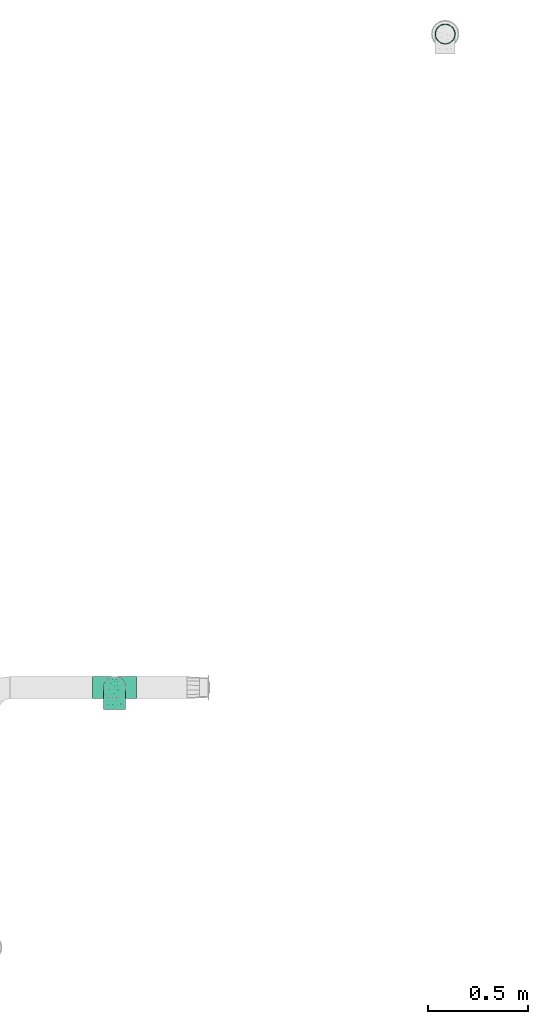
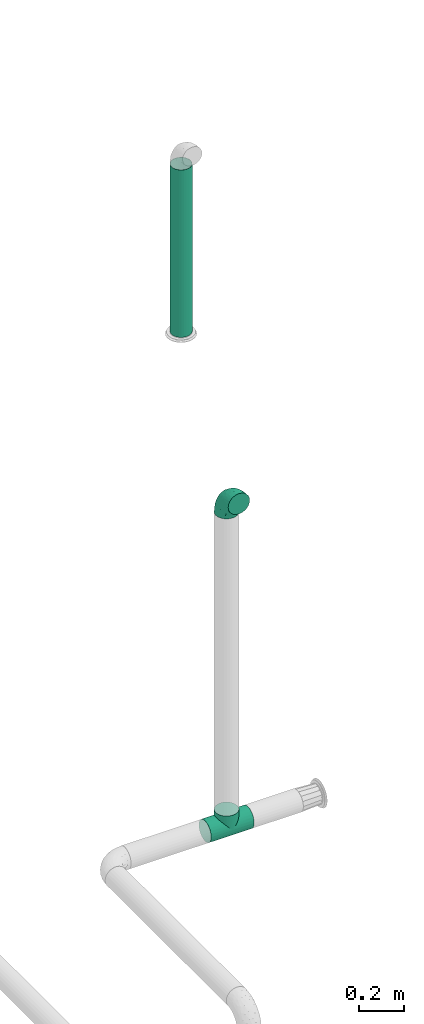
# One storey, part 45 of 103: 2 flow fittings, 1 flow segment.
"""IFC2X3 building model written with IfcOpenShell, lengths in millimetres."""

from ifc_helpers import new_model, entity, si_unit, converted_unit, derived_unit, direction, frame, origin_with_axes, origin_2d_with_axis, place, context, subcontext, project, spatial, hollow_circle, extrude, open_shell, surface_model, source, transform, mapped, material, layer, layer_set, layer_usage, type_object, element, save


model = new_model("IFC2X3")

# Units and contexts
model_context = context("Model", 3, precision=1e-05, world=origin_with_axes(), true_north=direction((0.0, 1.0)))
body_context = subcontext(model_context, "Body", "Model", "MODEL_VIEW")
ifc_project = project(units=[si_unit("AREAUNIT", "SQUARE_METRE"), si_unit("VOLUMEUNIT", "CUBIC_METRE", prefix="DECI"), si_unit("TIMEUNIT", "SECOND"), si_unit("THERMODYNAMICTEMPERATUREUNIT", "DEGREE_CELSIUS"), si_unit("PRESSUREUNIT", "PASCAL"), si_unit("MASSUNIT", "GRAM", prefix="KILO"), si_unit("LENGTHUNIT", "METRE", prefix="MILLI"), si_unit("POWERUNIT", "WATT"), si_unit("ELECTRICCURRENTUNIT", "AMPERE"), si_unit("ELECTRICVOLTAGEUNIT", "VOLT"), derived_unit("VOLUMETRICFLOWRATEUNIT", [(si_unit("VOLUMEUNIT", "CUBIC_METRE", prefix="DECI"), 1), (si_unit("TIMEUNIT", "SECOND"), -1)]), derived_unit("LINEARVELOCITYUNIT", [(si_unit("LENGTHUNIT", "METRE"), 1), (si_unit("TIMEUNIT", "SECOND"), -1)]), derived_unit("MASSDENSITYUNIT", [(si_unit("MASSUNIT", "GRAM", prefix="KILO"), 1), (si_unit("VOLUMEUNIT", "CUBIC_METRE"), -1)]), converted_unit("PLANEANGLEUNIT", "DEGREE", entity("IfcRatioMeasure", 0.01745), si_unit("PLANEANGLEUNIT", "RADIAN"), dimensions=[0, 0, 0, 0, 0, 0, 0])], contexts=[model_context])

# Site, building, storey
site_placement = place(None, origin_with_axes())
site = spatial("IfcSite", under=ifc_project, at=site_placement, CompositionType="ELEMENT")
building_placement = place(site_placement, origin_with_axes())
building = spatial("IfcBuilding", under=site, at=building_placement, Name="mc-building", CompositionType="ELEMENT")
storey_placement = place(building_placement, frame((0.0, 0.0, 5900.0), z_axis=(0.0, 0.0, 1.0), x_axis=(1.0, 0.0, 0.0)))
storey = spatial("IfcBuildingStorey", under=building, at=storey_placement, Name="3. Korrus", CompositionType="ELEMENT", Elevation=5900.0)

# Flow segment
ifc_material = material(Name="FZ1")
ifc_layer = layer(ifc_material, 0.0)
ifc_layer_set = layer_set([ifc_layer], Name="FZ1")
ifc_layer_usage = layer_usage(ifc_layer_set, "AXIS1", "POSITIVE", 0.0)
duct_segment_type = type_object("IfcDuctSegmentType", PredefinedType="RIGIDSEGMENT")
shared_shape_1 = source(origin_with_axes(), body_context, "Body", "SweptSolid", [
    extrude(hollow_circle(Radius=50.0, WallThickness=2.0, at=origin_2d_with_axis()), frame((0.0, 0.0, 0.0), z_axis=(1.0, 0.0, 0.0), x_axis=(0.0, 1.0, 0.0)), (0.0, 0.0, 1.0), 906.0),
])
flow_segment_placement = place(storey_placement, frame((14528.37491, 12733.41275, 2461.97044), z_axis=(1.0, 0.0, 0.0), x_axis=(0.0, 0.0, 1.0)))
element("IfcFlowSegment", 1, at=flow_segment_placement, inside=storey, type_object=duct_segment_type, material=ifc_layer_usage, context=body_context, shape_type="MappedRepresentation", body=[
    mapped(shared_shape_1, transform((0.0, 0.0, 0.0), scale=1.0)),
])

# Flow fittings
duct_fitting_type_1 = type_object("IfcDuctFittingType", PredefinedType="JUNCTION")
shared_shape_2 = source(origin_with_axes(), body_context, "Body", "SurfaceModel", [
    surface_model("IfcShellBasedSurfaceModel", [(-110.0, -38.89087, -38.89087), (-110.0, -55.0, 0.0), (-110.0, -27.5, -47.63139), (-110.0, -53.12592, -14.23505), (-110.0, -47.63139, -27.5), (-110.0, 47.63139, -27.5), (-110.0, 53.12592, 14.23505), (-110.0, 53.12592, -14.23505), (-110.0, 55.0, 0.0), (110.0, 38.89087, -38.89087), (110.0, 55.0, 0.0), (110.0, 27.5, -47.63139), (110.0, -38.89087, -38.89087), (110.0, -53.12592, 14.23505), (110.0, -47.63139, -27.5), (110.0, -55.0, 0.0), (110.0, -53.12592, -14.23505), (110.0, 53.12592, -14.23505), (110.0, 47.63139, -27.5), (-110.0, 38.89087, -38.89087), (-110.0, -14.23505, -53.12592), (-110.0, 0.0, -55.0), (-110.0, 27.5, -47.63139), (-110.0, 14.23505, -53.12592), (-110.0, -53.12592, 14.23505), (-110.0, -47.63139, 27.5), (-110.0, -38.89087, 38.89087), (-110.0, 14.23505, 53.12592), (-110.0, 27.5, 47.63139), (-55.0, 80.0, 0.0), (0.0, 80.0, -55.0), (-14.23505, 80.0, -53.12592), (-27.5, 80.0, -47.63139), (-38.89087, 80.0, -38.89087), (-47.63139, 80.0, -27.5), (38.89087, 80.0, -38.89087), (53.12592, 80.0, 14.23505), (27.5, 80.0, -47.63139), (14.23505, 80.0, -53.12592), (47.63139, 80.0, -27.5), (53.12592, 80.0, -14.23505), (55.0, 80.0, 0.0), (-53.12592, 80.0, -14.23505), (-53.12592, 80.0, 14.23505), (-47.63139, 80.0, 27.5), (-38.89087, 80.0, 38.89087), (0.0, 80.0, 55.0), (-27.5, 80.0, 47.63139), (-14.23505, 80.0, 53.12592), (47.63139, 80.0, 27.5), (38.89087, 80.0, 38.89087), (27.5, 80.0, 47.63139), (14.23505, 80.0, 53.12592), (-7.4066, 7.4066, 54.49901), (0.0, 0.0, 55.0), (-21.93978, 21.93978, 50.43457), (-14.74521, 14.74521, 52.98659), (-35.50357, 35.50357, 42.00591), (-28.89905, 28.89905, 46.79578), (-46.92319, 46.92319, 28.69171), (-41.58668, 41.58668, 35.99373), (-54.01174, 54.01174, 10.37938), (-54.06296, 80.0, 7.11752), (-55.0, 55.0, 0.0), (-51.19777, 51.19777, 20.0945), (-50.37866, 80.0, 20.86752), (-51.19777, 51.19777, -20.0945), (-54.01174, 54.01174, -10.37938), (-50.37866, 80.0, -20.86752), (-41.58668, 41.58668, -35.99373), (-46.92319, 46.92319, -28.69171), (-54.06296, 80.0, -7.11752), (-35.50357, 35.50357, -42.00591), (-14.74521, 14.74521, -52.98659), (-21.93978, 21.93978, -50.43457), (0.0, 0.0, -55.0), (-7.4066, 7.4066, -54.49901), (-28.89905, 28.89905, -46.79578), (7.4066, 7.4066, -54.49901), (21.93978, 21.93978, -50.43457), (14.74521, 14.74521, -52.98659), (35.50357, 35.50357, -42.00591), (28.89905, 28.89905, -46.79578), (46.92319, 46.92319, -28.69171), (41.58668, 41.58668, -35.99373), (54.01174, 54.01174, -10.37938), (54.06296, 80.0, -7.11752), (55.0, 55.0, 0.0), (51.19777, 51.19777, -20.0945), (50.37866, 80.0, -20.86752), (51.19777, 51.19777, 20.0945), (54.01174, 54.01174, 10.37938), (50.37866, 80.0, 20.86752), (41.58668, 41.58668, 35.99373), (46.92319, 46.92319, 28.69171), (54.06296, 80.0, 7.11752), (35.50357, 35.50357, 42.00591), (14.74521, 14.74521, 52.98659), (21.93978, 21.93978, 50.43457), (7.4066, 7.4066, 54.49901), (28.89905, 28.89905, 46.79578), (-110.0, -27.5, 47.63139), (-110.0, 0.0, 55.0), (-110.0, -14.23505, 53.12592), (-110.0, 47.63139, 27.5), (-110.0, 38.89087, 38.89087), (110.0, 0.0, -55.0), (110.0, 14.23505, -53.12592), (110.0, -14.23505, -53.12592), (110.0, -27.5, -47.63139), (110.0, 53.12592, 14.23505), (110.0, -47.63139, 27.5), (110.0, -38.89087, 38.89087), (110.0, 14.23505, 53.12592), (110.0, -27.5, 47.63139), (110.0, -14.23505, 53.12592), (110.0, 47.63139, 27.5), (110.0, 38.89087, 38.89087), (110.0, 27.5, 47.63139), (110.0, 0.0, 55.0)], [open_shell([[[0, 1, 2]], [[3, 1, 4]], [[5, 6, 7]], [[8, 7, 6]], [[9, 10, 11]], [[12, 13, 14]], [[15, 16, 13]], [[17, 10, 18]], [[19, 6, 5]], [[2, 1, 20]], [[19, 21, 6]], [[21, 19, 22]], [[22, 23, 21]], [[24, 25, 21]], [[21, 25, 26]], [[27, 28, 21]], [[29, 30, 31]], [[32, 29, 31]], [[29, 33, 34]], [[29, 32, 33]], [[35, 30, 36]], [[30, 35, 37]], [[37, 38, 30]], [[35, 36, 39]], [[39, 36, 40]], [[41, 40, 36]], [[42, 29, 34]], [[43, 44, 30]], [[30, 44, 45]], [[46, 30, 47]], [[30, 45, 47]], [[46, 47, 48]], [[49, 36, 30]], [[50, 49, 30]], [[51, 50, 30]], [[52, 51, 30]], [[52, 30, 46]], [[29, 43, 30]], [[46, 53, 54]], [[48, 55, 56]], [[48, 56, 53]], [[48, 53, 46]], [[57, 58, 47]], [[55, 48, 47]], [[45, 57, 47]], [[55, 47, 58]], [[44, 59, 60]], [[61, 62, 63]], [[43, 61, 64]], [[65, 43, 64]], [[44, 64, 59]], [[44, 60, 45]], [[43, 62, 61]], [[64, 44, 65]], [[29, 63, 62]], [[57, 45, 60]], [[42, 66, 67]], [[68, 34, 66]], [[34, 69, 70]], [[71, 42, 67]], [[34, 70, 66]], [[63, 71, 67]], [[29, 71, 63]], [[68, 66, 42]], [[34, 33, 69]], [[33, 72, 69]], [[31, 73, 74]], [[30, 75, 76]], [[31, 76, 73]], [[32, 77, 72]], [[77, 32, 74]], [[32, 31, 74]], [[31, 30, 76]], [[33, 32, 72]], [[30, 78, 75]], [[38, 79, 80]], [[38, 80, 78]], [[38, 78, 30]], [[81, 82, 37]], [[79, 38, 37]], [[35, 81, 37]], [[79, 37, 82]], [[39, 83, 84]], [[85, 86, 87]], [[40, 85, 88]], [[89, 40, 88]], [[39, 88, 83]], [[39, 84, 35]], [[40, 86, 85]], [[88, 39, 89]], [[41, 87, 86]], [[81, 35, 84]], [[36, 90, 91]], [[92, 49, 90]], [[49, 93, 94]], [[95, 36, 91]], [[49, 94, 90]], [[87, 95, 91]], [[95, 87, 41]], [[36, 92, 90]], [[49, 50, 93]], [[50, 96, 93]], [[52, 97, 98]], [[46, 54, 99]], [[52, 99, 97]], [[51, 100, 96]], [[100, 51, 98]], [[51, 52, 98]], [[52, 46, 99]], [[50, 51, 96]], [[1, 21, 20]], [[1, 0, 4]], [[101, 102, 26]], [[102, 21, 26]], [[102, 101, 103]], [[104, 6, 21]], [[105, 104, 21]], [[105, 21, 28]], [[21, 102, 27]], [[1, 24, 21]], [[106, 107, 108]], [[108, 13, 109]], [[109, 13, 12]], [[108, 10, 110]], [[107, 11, 10]], [[9, 18, 10]], [[10, 108, 107]], [[16, 14, 13]], [[108, 111, 13]], [[108, 112, 111]], [[108, 113, 114]], [[114, 112, 108]], [[113, 115, 114]], [[108, 110, 116]], [[108, 116, 117]], [[108, 117, 118]], [[113, 108, 118]], [[113, 119, 115]], [[115, 119, 54]], [[114, 115, 101]], [[103, 54, 102]], [[115, 54, 103]], [[103, 101, 115]], [[101, 26, 114]], [[111, 112, 25]], [[13, 111, 24]], [[15, 13, 1]], [[25, 112, 26]], [[24, 111, 25]], [[24, 1, 13]], [[114, 26, 112]], [[16, 15, 3]], [[14, 16, 4]], [[3, 15, 1]], [[4, 16, 3]], [[4, 0, 14]], [[0, 12, 14]], [[109, 12, 2]], [[108, 109, 20]], [[106, 108, 75]], [[20, 109, 2]], [[20, 21, 75]], [[20, 75, 108]], [[0, 2, 12]], [[21, 76, 75]], [[23, 74, 73]], [[23, 73, 76]], [[23, 76, 21]], [[72, 77, 22]], [[74, 23, 22]], [[19, 72, 22]], [[74, 22, 77]], [[5, 70, 69]], [[7, 67, 66]], [[5, 66, 70]], [[5, 69, 19]], [[7, 8, 67]], [[66, 5, 7]], [[63, 67, 8]], [[72, 19, 69]], [[107, 106, 78]], [[79, 11, 107]], [[9, 11, 81]], [[11, 82, 81]], [[106, 75, 78]], [[107, 80, 79]], [[11, 79, 82]], [[80, 107, 78]], [[18, 9, 84]], [[17, 18, 88]], [[10, 17, 85]], [[18, 84, 83]], [[17, 88, 85]], [[10, 85, 87]], [[88, 18, 83]], [[81, 84, 9]], [[110, 10, 91]], [[116, 110, 90]], [[117, 116, 93]], [[10, 87, 91]], [[116, 90, 94]], [[116, 94, 93]], [[90, 110, 91]], [[93, 96, 117]], [[118, 96, 100]], [[117, 96, 118]], [[113, 118, 98]], [[119, 113, 99]], [[118, 100, 98]], [[113, 97, 99]], [[119, 99, 54]], [[97, 113, 98]], [[6, 64, 61]], [[104, 60, 59]], [[104, 59, 64]], [[8, 61, 63]], [[61, 8, 6]], [[6, 104, 64]], [[104, 105, 60]], [[105, 57, 60]], [[27, 56, 55]], [[102, 54, 53]], [[27, 53, 56]], [[28, 58, 57]], [[58, 28, 55]], [[28, 27, 55]], [[27, 102, 53]], [[105, 28, 57]]])]),
])
flow_fitting_1_placement = place(storey_placement, frame((12881.59664, 9477.62755, 2345.0), z_axis=(0.0, 1.0, 0.0), x_axis=(-1.0, 0.0, 0.0)))
element("IfcFlowFitting", 2, at=flow_fitting_1_placement, inside=storey, type_object=duct_fitting_type_1, context=body_context, shape_type="MappedRepresentation", body=[
    mapped(shared_shape_2, transform((0.0, 0.0, 0.0), scale=1.0)),
])
duct_fitting_type_2 = type_object("IfcDuctFittingType", Name="BU", PredefinedType="BEND")
shared_shape_3 = source(origin_with_axes(), body_context, "Body", "SurfaceModel", [
    surface_model("IfcShellBasedSurfaceModel", [(-110.0, -38.89087, -38.89087), (-110.0, -55.0, 0.0), (-110.0, -27.5, -47.63139), (-110.0, -53.12592, -14.23505), (-110.0, -47.63139, -27.5), (-110.0, 47.63139, -27.5), (-110.0, 53.12592, 14.23505), (-110.0, 53.12592, -14.23505), (-110.0, -14.23505, -53.12592), (-110.0, 0.0, -55.0), (-110.0, 38.89087, -38.89087), (-110.0, 27.5, -47.63139), (-110.0, 14.23505, -53.12592), (-110.0, 55.0, 0.0), (-110.0, -53.12592, 14.23505), (-110.0, -47.63139, 27.5), (-110.0, -38.89087, 38.89087), (-110.0, 0.0, 55.0), (-110.0, -27.5, 47.63139), (-110.0, -14.23505, 53.12592), (-110.0, 38.89087, 38.89087), (-110.0, 47.63139, 27.5), (-110.0, 27.5, 47.63139), (-110.0, 14.23505, 53.12592), (0.0, -110.0, -55.0), (14.23505, -110.0, -53.12592), (-14.23505, -110.0, -53.12592), (-53.12592, -110.0, 14.23505), (-27.5, -110.0, -47.63139), (-47.63139, -110.0, -27.5), (-38.89087, -110.0, -38.89087), (55.0, -110.0, 0.0), (53.12592, -110.0, 14.23505), (38.89087, -110.0, -38.89087), (27.5, -110.0, -47.63139), (53.12592, -110.0, -14.23505), (47.63139, -110.0, -27.5), (-53.12592, -110.0, -14.23505), (-47.63139, -110.0, 27.5), (-38.89087, -110.0, 38.89087), (14.23505, -110.0, 53.12592), (-27.5, -110.0, 47.63139), (-14.23505, -110.0, 53.12592), (47.63139, -110.0, 27.5), (38.89087, -110.0, 38.89087), (27.5, -110.0, 47.63139), (0.0, -110.0, 55.0), (-55.0, -110.0, 0.0), (-60.44912, -32.56953, 51.94617), (-76.6405, -38.18013, 45.55988), (-64.21732, -48.68956, 43.63444), (-90.15553, -11.94394, 54.09138), (-76.00813, -5.38378, 55.0), (-70.18771, -18.55163, 54.03432), (-78.5998, -26.77405, 50.81338), (-93.27622, -45.77614, 33.48188), (-75.55424, -54.2118, 32.41257), (-96.12334, -22.13664, 50.81337), (-32.04182, -59.64019, 52.24446), (-18.36258, -70.48427, 54.04484), (-21.00813, -45.34362, 55.0), (-63.60674, -66.07878, 29.97482), (-74.66383, -63.08407, 19.92123), (-63.88653, -74.77858, 17.99134), (-93.11138, -56.59448, 10.50359), (-99.597, -52.72185, 18.52927), (-98.21577, -57.34403, 0.0), (-53.42855, -92.60092, 21.04759), (-88.54852, -54.8376, 21.04759), (-5.38378, -76.00813, 55.0), (-11.86161, -90.23965, 54.10313), (-56.64619, -93.12774, 10.22088), (-57.34403, -98.21577, 0.0), (-44.60838, -44.60838, 52.13415), (-45.34362, -21.00813, 55.0), (-92.68484, -35.46673, 43.63443), (-22.25266, -95.40765, 50.81337), (-27.23711, -77.39884, 50.81337), (-43.70931, -69.58671, 44.47149), (-35.97783, -90.61597, 43.63443), (-58.67786, -84.31125, 16.04456), (-57.2828, -79.3123, 24.9774), (-82.93277, -60.36161, 12.91784), (-49.88337, -54.51816, 47.224), (-74.57753, -66.83759, 9.55742), (-45.35812, -94.97281, 33.48188), (-59.18663, -88.95241, 0.0), (-51.517, -78.6292, 33.48188), (-65.14788, -80.03077, 0.0), (-56.45322, -62.06476, 39.63545), (-88.95241, -59.18663, 0.0), (-80.03077, -65.14788, 0.0), (-71.10913, -71.10913, 0.0), (-94.9309, -45.36788, -33.48188), (-93.11358, -56.60141, -10.46614), (-99.64997, -52.79499, -18.30015), (-79.99933, -46.56772, -37.92748), (-90.20425, -36.08686, -43.63443), (-45.34362, -21.00813, -55.0), (-72.75364, -19.68651, -53.60527), (-76.00813, -5.38378, -55.0), (-21.00813, -45.34362, -55.0), (-5.38378, -76.00813, -55.0), (-21.91957, -65.12078, -53.85897), (-35.41876, -92.89265, -43.63443), (-91.10309, -11.02766, -54.21832), (-45.77614, -93.27622, -33.48188), (-90.50474, -23.21022, -50.81337), (-70.92854, -33.31794, -49.51754), (-78.52933, -63.35627, -11.73997), (-24.91508, -84.05606, -50.81337), (-88.78941, -54.74452, -21.04759), (-63.49062, -67.59111, -28.46929), (-73.36422, -62.46673, -22.94182), (-69.59921, -57.34866, -33.48187), (-56.59448, -93.11138, -10.50359), (-54.10679, -75.85581, -32.31867), (-54.8376, -88.54852, -21.04759), (-57.75956, -31.09612, -52.80882), (-52.72185, -99.597, -18.52927), (-12.62913, -89.46304, -53.99097), (-34.46825, -66.46123, -50.04329), (-43.9837, -43.9837, -52.42279), (-65.78527, -72.58348, -17.68796), (-57.47001, -51.99467, -44.91465), (-70.34468, -43.65295, -44.21951), (-60.72547, -82.29174, -12.88567), (-42.34915, -74.24548, -43.63444), (-57.25194, -63.5016, -38.08211), (-80.95344, -53.56991, -29.32027), (-52.32891, -4.55257, -54.0482), (14.95561, -36.05775, -42.26543), (14.88266, -20.92917, -33.7947), (32.52942, -47.13398, -30.48571), (19.3559, -65.35825, -48.00507), (30.24048, -70.09027, -41.7461), (-28.49299, 30.5778, -16.4009), (-47.13398, 32.52942, -30.48571), (-70.35075, 46.44478, -19.5952), (-22.4954, -22.4954, -53.25347), (-4.55257, -52.32891, -54.0482), (-75.47368, 11.22546, -52.60718), (-81.32209, 51.5606, -9.98467), (-70.09027, 30.24048, -41.7461), (-80.81763, 41.84862, -32.14655), (-9.15831, 10.852, -27.8997), (-36.05774, 14.95561, -42.26543), (-65.35825, 19.3559, -48.00507), (3.94376, -43.9333, -50.53315), (11.22546, -75.47368, -52.60718), (-43.9333, 3.94376, -50.53315), (-13.39742, -13.39743, -48.13058), (50.20582, -74.51695, -9.9731), (41.8609, -47.82256, -9.92641), (49.37776, -67.29486, 0.0), (18.93131, -11.7156, -17.56239), (-1.23348, 12.25375, -12.18106), (-27.5, 32.89419, 0.0), (41.84862, -80.81763, -32.14655), (46.44478, -70.35075, -19.5952), (35.70604, -41.31408, -20.38235), (6.67262, 6.67262, 0.0), (32.89419, -27.5, 0.0), (-50.36265, 42.95545, -9.51562), (-67.29486, 49.37776, 0.0), (-5.47251, -5.47251, -39.92906), (-70.35075, 46.44478, 19.5952), (-74.51695, 50.20582, 9.9731), (-47.13398, 32.52942, 30.48571), (-41.31407, 35.70604, 20.38235), (-80.81763, 41.84862, 32.14655), (11.22546, -75.47368, 52.60718), (-4.55257, -52.32891, 54.0482), (-36.05774, 14.95561, 42.26543), (-65.35825, 19.3559, 48.00507), (-43.9333, 3.94376, 50.53315), (-70.09027, 30.24048, 41.7461), (-11.7156, 18.93131, 17.56239), (12.25375, -1.23348, 12.18106), (30.5778, -28.49299, 16.4009), (42.95545, -50.36265, 9.51562), (51.5606, -81.32209, 9.98467), (-52.32891, -4.55257, 54.0482), (-75.47368, 11.22546, 52.60718), (-13.39742, -13.39743, 48.13058), (-22.4954, -22.4954, 53.25347), (3.94376, -43.9333, 50.53315), (-20.92916, 14.88266, 33.79469), (10.852, -9.15831, 27.8997), (-47.82256, 41.8609, 9.92641), (32.52942, -47.13398, 30.48571), (46.44478, -70.35075, 19.5952), (41.84862, -80.81763, 32.14655), (14.95561, -36.05775, 42.26543), (19.3559, -65.35825, 48.00507), (30.24048, -70.09027, 41.7461), (-5.47251, -5.47251, 39.92906)], [open_shell([[[0, 1, 2]], [[3, 1, 4]], [[5, 6, 7]], [[8, 1, 9]], [[2, 1, 8]], [[4, 1, 0]], [[10, 9, 6]], [[9, 10, 11]], [[11, 12, 9]], [[6, 5, 10]], [[7, 6, 13]], [[14, 15, 9]], [[9, 15, 16]], [[17, 16, 18]], [[9, 16, 17]], [[19, 17, 18]], [[9, 20, 21]], [[6, 9, 21]], [[9, 22, 20]], [[23, 22, 9]], [[17, 23, 9]], [[9, 1, 14]], [[24, 25, 26]], [[26, 27, 28]], [[29, 30, 27]], [[28, 27, 30]], [[26, 31, 32]], [[33, 31, 34]], [[25, 34, 31]], [[35, 31, 36]], [[33, 36, 31]], [[31, 26, 25]], [[29, 27, 37]], [[38, 27, 26]], [[39, 38, 26]], [[40, 41, 26]], [[41, 39, 26]], [[40, 42, 41]], [[43, 44, 26]], [[43, 26, 32]], [[44, 45, 26]], [[26, 45, 40]], [[40, 46, 42]], [[47, 37, 27]], [[48, 49, 50]], [[51, 52, 17]], [[48, 53, 54]], [[49, 55, 56]], [[16, 15, 55]], [[18, 57, 19]], [[58, 59, 60]], [[61, 62, 63]], [[64, 65, 14]], [[53, 51, 54]], [[66, 64, 14]], [[27, 38, 67]], [[65, 68, 55]], [[68, 65, 64]], [[69, 59, 70]], [[71, 72, 27]], [[73, 60, 74]], [[55, 49, 75]], [[42, 70, 76]], [[51, 57, 54]], [[77, 78, 79]], [[42, 76, 41]], [[46, 70, 42]], [[55, 68, 56]], [[75, 18, 16]], [[77, 79, 76]], [[80, 67, 81]], [[68, 82, 62]], [[83, 78, 58]], [[82, 84, 62]], [[39, 79, 85]], [[71, 67, 80]], [[72, 71, 86]], [[67, 85, 87]], [[88, 80, 63]], [[39, 41, 79]], [[87, 79, 78]], [[55, 75, 16]], [[50, 89, 83]], [[38, 39, 85]], [[56, 68, 62]], [[61, 87, 89]], [[48, 50, 83]], [[18, 75, 57]], [[54, 75, 49]], [[38, 85, 67]], [[85, 79, 87]], [[56, 62, 61]], [[50, 56, 89]], [[87, 61, 81]], [[90, 64, 66]], [[14, 1, 66]], [[91, 92, 84]], [[82, 90, 91]], [[90, 82, 64]], [[62, 84, 63]], [[84, 82, 91]], [[64, 82, 68]], [[65, 15, 14]], [[15, 65, 55]], [[72, 47, 27]], [[86, 71, 80]], [[67, 71, 27]], [[88, 63, 92]], [[63, 80, 81]], [[63, 81, 61]], [[87, 81, 67]], [[41, 76, 79]], [[70, 59, 77]], [[76, 70, 77]], [[69, 70, 46]], [[77, 59, 58]], [[59, 69, 60]], [[77, 58, 78]], [[73, 58, 60]], [[19, 57, 51]], [[54, 57, 75]], [[19, 51, 17]], [[53, 52, 51]], [[53, 74, 52]], [[73, 74, 48]], [[53, 48, 74]], [[83, 73, 48]], [[73, 83, 58]], [[78, 83, 89]], [[78, 89, 87]], [[61, 89, 56]], [[54, 49, 48]], [[50, 49, 56]], [[88, 86, 80]], [[63, 84, 92]], [[93, 4, 0]], [[66, 94, 90]], [[95, 94, 3]], [[96, 93, 97]], [[98, 99, 100]], [[0, 2, 97]], [[101, 102, 103]], [[104, 28, 30]], [[9, 105, 8]], [[30, 106, 104]], [[107, 105, 99]], [[97, 107, 108]], [[94, 109, 90]], [[2, 8, 107]], [[94, 66, 3]], [[110, 26, 28]], [[94, 111, 109]], [[112, 113, 114]], [[72, 115, 37]], [[116, 106, 117]], [[98, 118, 99]], [[119, 115, 117]], [[115, 119, 37]], [[110, 120, 26]], [[103, 110, 121]], [[117, 106, 119]], [[120, 110, 103]], [[98, 101, 122]], [[117, 123, 116]], [[108, 124, 125]], [[126, 117, 115]], [[30, 29, 106]], [[120, 102, 24]], [[110, 104, 127]], [[97, 125, 96]], [[118, 122, 124]], [[124, 127, 128]], [[93, 0, 97]], [[86, 126, 115]], [[127, 106, 116]], [[129, 113, 111]], [[4, 93, 95]], [[114, 129, 96]], [[28, 104, 110]], [[127, 104, 106]], [[2, 107, 97]], [[108, 107, 99]], [[118, 108, 99]], [[100, 99, 105]], [[128, 112, 114]], [[127, 124, 121]], [[66, 1, 3]], [[91, 90, 109]], [[95, 111, 94]], [[109, 123, 92]], [[114, 113, 129]], [[111, 95, 93]], [[95, 3, 4]], [[86, 115, 72]], [[37, 47, 72]], [[88, 92, 123]], [[123, 117, 126]], [[126, 88, 123]], [[88, 126, 86]], [[119, 29, 37]], [[29, 119, 106]], [[111, 93, 129]], [[124, 114, 125]], [[100, 105, 9]], [[8, 105, 107]], [[108, 118, 124]], [[122, 118, 98]], [[96, 129, 93]], [[109, 111, 113]], [[113, 123, 109]], [[116, 123, 112]], [[113, 112, 123]], [[116, 112, 128]], [[116, 128, 127]], [[124, 128, 114]], [[103, 122, 101]], [[127, 121, 110]], [[121, 122, 103]], [[122, 121, 124]], [[26, 120, 24]], [[102, 120, 103]], [[108, 125, 97]], [[109, 92, 91]], [[96, 125, 114]], [[100, 130, 98]], [[131, 132, 133]], [[134, 135, 34]], [[136, 137, 138]], [[101, 139, 140]], [[9, 141, 100]], [[138, 7, 142]], [[137, 143, 144]], [[142, 7, 13]], [[145, 146, 137]], [[146, 147, 143]], [[5, 138, 144]], [[7, 138, 5]], [[5, 144, 10]], [[140, 148, 149]], [[143, 11, 10]], [[147, 12, 11]], [[100, 141, 130]], [[98, 139, 101]], [[148, 134, 149]], [[139, 150, 151]], [[152, 153, 154]], [[150, 139, 130]], [[25, 24, 149]], [[141, 12, 147]], [[132, 145, 155]], [[156, 136, 157]], [[158, 33, 135]], [[148, 139, 151]], [[36, 33, 158]], [[34, 135, 33]], [[159, 160, 153]], [[160, 159, 133]], [[137, 146, 143]], [[152, 154, 31]], [[137, 136, 145]], [[161, 162, 155]], [[133, 159, 158]], [[134, 148, 131]], [[163, 164, 157]], [[163, 142, 164]], [[102, 101, 140]], [[162, 154, 153]], [[159, 35, 36]], [[155, 156, 161]], [[131, 165, 132]], [[155, 145, 156]], [[98, 130, 139]], [[150, 130, 141]], [[147, 150, 141]], [[9, 12, 141]], [[149, 24, 102]], [[148, 140, 139]], [[140, 149, 102]], [[34, 25, 134]], [[146, 151, 150]], [[143, 147, 11]], [[147, 146, 150]], [[145, 165, 146]], [[25, 149, 134]], [[135, 134, 131]], [[135, 131, 133]], [[151, 165, 131]], [[148, 151, 131]], [[165, 151, 146]], [[160, 133, 132]], [[132, 165, 145]], [[36, 158, 159]], [[133, 158, 135]], [[10, 144, 143]], [[137, 144, 138]], [[162, 153, 155]], [[159, 153, 152]], [[160, 155, 153]], [[155, 160, 132]], [[152, 35, 159]], [[35, 152, 31]], [[136, 138, 163]], [[164, 142, 13]], [[142, 163, 138]], [[136, 163, 157]], [[161, 156, 157]], [[136, 156, 145]], [[166, 6, 21]], [[167, 164, 13]], [[166, 168, 169]], [[170, 168, 166]], [[69, 171, 172]], [[173, 174, 175]], [[174, 176, 22]], [[161, 157, 177]], [[170, 20, 176]], [[21, 20, 170]], [[178, 179, 162]], [[180, 181, 154]], [[182, 175, 183]], [[183, 23, 17]], [[184, 185, 186]], [[74, 185, 182]], [[52, 74, 182]], [[187, 188, 177]], [[166, 169, 189]], [[190, 179, 188]], [[22, 176, 20]], [[180, 154, 162]], [[32, 191, 43]], [[192, 44, 43]], [[43, 191, 192]], [[32, 31, 181]], [[193, 194, 195]], [[194, 40, 45]], [[190, 193, 195]], [[45, 44, 195]], [[69, 46, 171]], [[74, 60, 185]], [[157, 164, 189]], [[167, 189, 164]], [[172, 60, 69]], [[185, 172, 186]], [[173, 187, 168]], [[191, 32, 181]], [[190, 195, 192]], [[179, 190, 191]], [[175, 174, 183]], [[171, 40, 194]], [[188, 193, 190]], [[175, 185, 184]], [[177, 178, 161]], [[173, 196, 187]], [[177, 188, 178]], [[60, 172, 185]], [[186, 172, 171]], [[194, 186, 171]], [[46, 40, 171]], [[183, 17, 52]], [[175, 182, 185]], [[182, 183, 52]], [[22, 23, 174]], [[193, 184, 186]], [[195, 194, 45]], [[194, 193, 186]], [[188, 196, 193]], [[23, 183, 174]], [[176, 174, 173]], [[176, 173, 168]], [[184, 196, 173]], [[175, 184, 173]], [[196, 184, 193]], [[169, 168, 187]], [[187, 196, 188]], [[21, 170, 166]], [[168, 170, 176]], [[44, 192, 195]], [[190, 192, 191]], [[157, 189, 177]], [[166, 189, 167]], [[169, 177, 189]], [[177, 169, 187]], [[167, 6, 166]], [[6, 167, 13]], [[179, 191, 180]], [[154, 181, 31]], [[181, 180, 191]], [[179, 180, 162]], [[161, 178, 162]], [[179, 178, 188]]])]),
])
flow_fitting_2_placement = place(storey_placement, frame((12881.59664, 9477.62755, 4144.0), z_axis=(-1.0, 0.0, 0.0), x_axis=(0.0, 0.0, 1.0)))
element("IfcFlowFitting", 3, at=flow_fitting_2_placement, inside=storey, type_object=duct_fitting_type_2, Name="BU", context=body_context, shape_type="MappedRepresentation", body=[
    mapped(shared_shape_3, transform((0.0, 0.0, 0.0), scale=1.0)),
])

save(model, "model.ifc")
